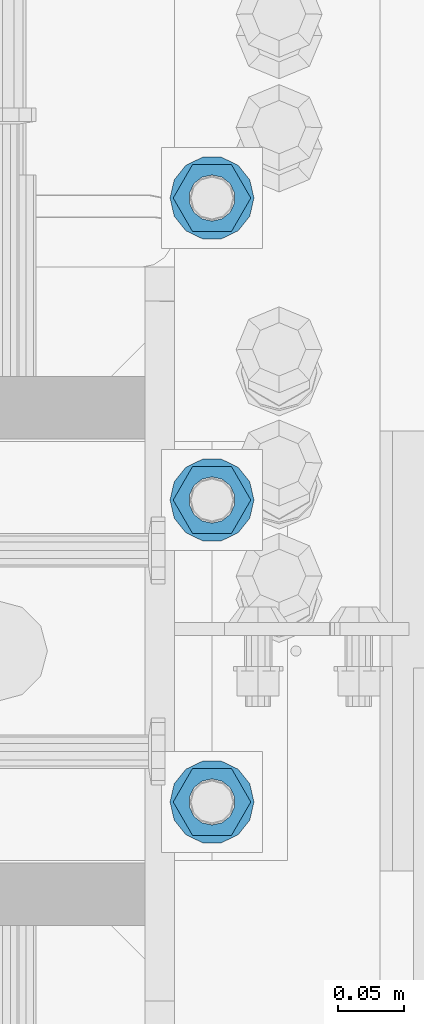
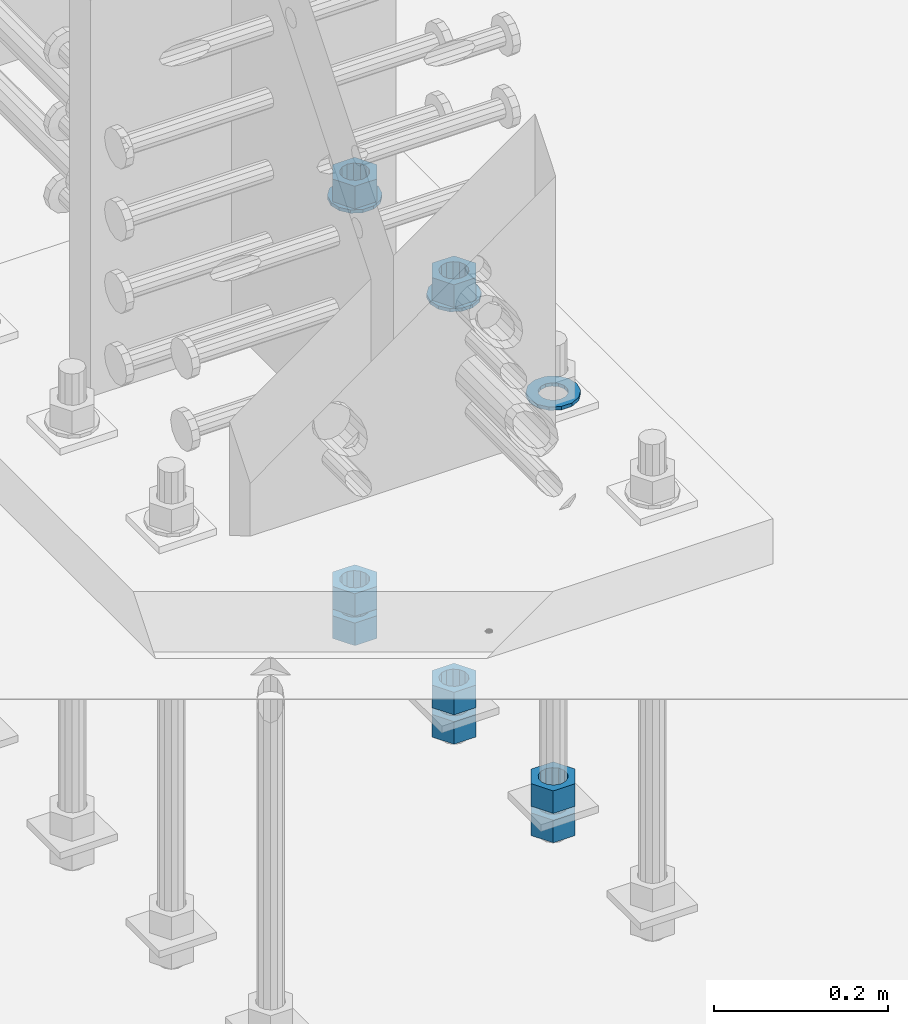
# One storey, part 1009 of 1763: 11 columns, 1 element without a shape of its own.
"""IFC2X3 building model written with IfcOpenShell, lengths in millimetres."""

import ifcopenshell
import ifcopenshell.guid

model = None  # the IFC model being written
_history = None  # IfcOwnerHistory: only IFC2X3 demands one
_inside = {}  # id of a spatial element -> (the spatial element, [elements in it])
_under = {}  # id of a project, library or spatial element -> (it, [spatial elements below it])
_declared = {}  # id of a project -> (the project, [libraries it declares])
_typed = {}  # id of a type object -> (the type object, [elements of that type])
_made_of = {}  # id of a material, layer set ... -> (it, [elements and type objects made of it])


def new_model(schema):
    """Start an empty IFC model of exactly this schema.

    Asked for "IFC4X3", IfcOpenShell would pick the latest addendum, in which some entities
    have other attributes; the version numbers below select the first issue.
    IFC2X3 requires an IfcOwnerHistory on every rooted entity: one is made here for all.
    """
    global model, _history
    if schema == "IFC4X3":
        model = ifcopenshell.file(schema_version=(4, 3, 0, 0))
    else:
        model = ifcopenshell.file(schema=schema)
    _inside.clear()
    _under.clear()
    _declared.clear()
    _typed.clear()
    _made_of.clear()
    _history = None
    if model.schema == "IFC2X3":
        org = make("IfcOrganization", Name="unknown")
        user = make(
            "IfcPersonAndOrganization",
            ThePerson=make("IfcPerson", FamilyName="unknown"),
            TheOrganization=org,
        )
        app = make(
            "IfcApplication",
            ApplicationDeveloper=org,
            Version="unknown",
            ApplicationFullName="unknown",
            ApplicationIdentifier="unknown",
        )
        _history = make(
            "IfcOwnerHistory",
            OwningUser=user,
            OwningApplication=app,
            ChangeAction="ADDED",
            CreationDate=0,
        )
    return model


def make(cls, **values):
    """One entity of the class cls with the attributes given. An attribute that is None is left unset."""
    return model.create_entity(
        cls, **{name: value for name, value in values.items() if value is not None}
    )


def rooted(cls, **values):
    """An entity with a GlobalId (a new one), such as an element, a storey or a relation."""
    return make(cls, GlobalId=ifcopenshell.guid.new(), OwnerHistory=_history, **values)


def si_unit(unit_type, name, prefix=None):
    """IfcSIUnit, for example si_unit("LENGTHUNIT", "METRE", prefix="MILLI")."""
    return make("IfcSIUnit", UnitType=unit_type, Prefix=prefix, Name=name)


def assignment(units):
    """IfcUnitAssignment: the units of a project."""
    return None if units is None else make("IfcUnitAssignment", Units=units)


def point(xyz):
    """IfcCartesianPoint."""
    return None if xyz is None else make("IfcCartesianPoint", Coordinates=xyz)


def direction(xyz):
    """IfcDirection."""
    return None if xyz is None else make("IfcDirection", DirectionRatios=xyz)


def frame(location, z_axis=None, x_axis=None):
    """IfcAxis2Placement3D, a coordinate frame: its origin and axes. An axis left out is left unset."""
    return make(
        "IfcAxis2Placement3D",
        Location=point(location),
        Axis=direction(z_axis),
        RefDirection=direction(x_axis),
    )


def origin_with_axes():
    """The frame at (0, 0, 0) with the z axis (0, 0, 1) and the x axis (1, 0, 0) written out."""
    return frame((0.0, 0.0, 0.0), z_axis=(0.0, 0.0, 1.0), x_axis=(1.0, 0.0, 0.0))


def place(relative_to, where):
    """IfcLocalPlacement: puts the frame where relative to a parent placement (None: the world)."""
    return make(
        "IfcLocalPlacement", PlacementRelTo=relative_to, RelativePlacement=where
    )


def context(
    kind, dimensions, precision=None, world=None, true_north=None, identifier=None
):
    """IfcGeometricRepresentationContext, for example the 3D "Model" context."""
    return make(
        "IfcGeometricRepresentationContext",
        ContextIdentifier=identifier,
        ContextType=kind,
        CoordinateSpaceDimension=dimensions,
        Precision=precision,
        WorldCoordinateSystem=world,
        TrueNorth=true_north,
    )


def subcontext(parent, identifier, kind, view, scale=None):
    """IfcGeometricRepresentationSubContext, for example "Body" below "Model"."""
    return make(
        "IfcGeometricRepresentationSubContext",
        ContextIdentifier=identifier,
        ContextType=kind,
        ParentContext=parent,
        TargetScale=scale,
        TargetView=view,
    )


def project(units=None, contexts=None):
    """IfcProject with its units and contexts."""
    return rooted(
        "IfcProject",
        Name="project",
        RepresentationContexts=contexts,
        UnitsInContext=assignment(units),
    )


def spatial(cls, under=None, at=None, **own):
    """A site, building, storey or space (cls), placed at a placement, below another one or the project."""
    s = rooted(cls, ObjectPlacement=at, **own)
    if under is not None:
        _under.setdefault(under.id(), (under, []))[1].append(s)
    return s


def faces_of(points, faces, orient=None, outer=None):
    """IfcFace entities. A face is a list of loops; a loop is a list of indices into points, from 0.

    orient and outer hold one flag for each loop. By default every Orientation is true, the
    first loop of a face is its IfcFaceOuterBound and the others are IfcFaceBound.
    """
    made = []
    for i, loops in enumerate(faces):
        bounds = []
        for j, loop in enumerate(loops):
            is_outer = j == 0 if outer is None else outer[i][j]
            bounds.append(
                make(
                    "IfcFaceOuterBound" if is_outer else "IfcFaceBound",
                    Bound=make("IfcPolyLoop", Polygon=[points[k] for k in loop]),
                    Orientation=True if orient is None else orient[i][j],
                )
            )
        made.append(make("IfcFace", Bounds=bounds))
    return made


def faceted_brep(points, faces, orient=None, outer=None, voids=None):
    """IfcFacetedBrep: a solid bounded by flat faces; with voids (closed shells), ...WithVoids."""
    shared = [point(p) for p in points]
    hull = make("IfcClosedShell", CfsFaces=faces_of(shared, faces, orient, outer))
    if voids is None:
        return make("IfcFacetedBrep", Outer=hull)
    return make(
        "IfcFacetedBrepWithVoids",
        Outer=hull,
        Voids=[
            make(cls, CfsFaces=faces_of(shared, fs, o, b)) for cls, fs, o, b in voids
        ],
    )


def shape(context_of_items, identifier, shape_type, items):
    """IfcShapeRepresentation: the items that make up one representation, for example the "Body"."""
    return make(
        "IfcShapeRepresentation",
        ContextOfItems=context_of_items,
        RepresentationIdentifier=identifier,
        RepresentationType=shape_type,
        Items=items,
    )


def material(Name=None, Category=None):
    """IfcMaterial."""
    return make("IfcMaterial", Name=Name, Category=Category)


def made_of(thing, what):
    """Note that an element or type object is made of a material, layer set ...; save() writes the relation."""
    if what is not None:
        _made_of.setdefault(what.id(), (what, []))[1].append(thing)
    return thing


def type_object(cls, material=None, **own):
    """A type object (cls), such as IfcWallType, which elements share."""
    return made_of(rooted(cls, **own), material)


def element(
    cls,
    number,
    at=None,
    inside=None,
    cuts=None,
    type_object=None,
    material=None,
    context=None,
    identifier="Body",
    shape_type=None,
    held_by="IfcProductDefinitionShape",
    body=None,
    shapes=None,
    **own,
):
    """One element of the class cls, such as IfcWall. Its Tag is "e" and its number.

    at: its placement. inside: the storey or other place that contains it. cuts: it is an
    opening in that element (IfcRelVoidsElement). A single representation is given by context,
    identifier, shape_type and body (its items); several are given by shapes. held_by: the class
    of the entity that holds the representations. save() writes the other relations.
    """
    e = rooted(cls, Tag="e%d" % number, ObjectPlacement=at, **own)
    if body is not None:
        shapes = [shape(context, identifier, shape_type, body)]
    if shapes is not None:
        e.Representation = make(held_by, Representations=shapes)
    if inside is not None:
        _inside.setdefault(inside.id(), (inside, []))[1].append(e)
    if cuts is not None:
        rooted(
            "IfcRelVoidsElement", RelatingBuildingElement=cuts, RelatedOpeningElement=e
        )
    if type_object is not None:
        _typed.setdefault(type_object.id(), (type_object, []))[1].append(e)
    return made_of(e, material)


def aggregate(whole, parts):
    """IfcRelAggregates: a whole, such as a stair, and the parts it consists of."""
    return rooted("IfcRelAggregates", RelatingObject=whole, RelatedObjects=parts)


def save(model, path):
    """Write the relations noted so far, then the file.

    IfcRelAggregates (storeys below a building ...), IfcRelContainedInSpatialStructure (elements
    in a storey), IfcRelDefinesByType, IfcRelAssociatesMaterial and IfcRelDeclares: one each for
    every whole, place, type object, material and project.
    """
    for whole, parts in _under.values():
        aggregate(whole, parts)
    for where, things in _inside.values():
        rooted(
            "IfcRelContainedInSpatialStructure",
            RelatedElements=things,
            RelatingStructure=where,
        )
    for kind, things in _typed.values():
        rooted("IfcRelDefinesByType", RelatedObjects=things, RelatingType=kind)
    for what, things in _made_of.values():
        rooted("IfcRelAssociatesMaterial", RelatedObjects=things, RelatingMaterial=what)
    for by, libraries in _declared.values():
        rooted("IfcRelDeclares", RelatingContext=by, RelatedDefinitions=libraries)
    model.write(path)


model = new_model("IFC2X3")

# Units and contexts
model_context = context("Model", 3, precision=1e-05, world=origin_with_axes())
body_context = subcontext(model_context, "Body", "Model", "MODEL_VIEW")
ifc_project = project(units=[si_unit("LENGTHUNIT", "METRE", prefix="MILLI"), si_unit("AREAUNIT", "SQUARE_METRE"), si_unit("VOLUMEUNIT", "CUBIC_METRE"), si_unit("MASSUNIT", "GRAM", prefix="KILO"), si_unit("TIMEUNIT", "SECOND"), si_unit("PLANEANGLEUNIT", "RADIAN"), si_unit("SOLIDANGLEUNIT", "STERADIAN"), si_unit("THERMODYNAMICTEMPERATUREUNIT", "DEGREE_CELSIUS"), si_unit("LUMINOUSINTENSITYUNIT", "LUMEN")], contexts=[model_context])

# Site, building, storey
site_placement = place(None, origin_with_axes())
site = spatial("IfcSite", under=ifc_project, at=site_placement, CompositionType="ELEMENT")
building_placement = place(site_placement, origin_with_axes())
building = spatial("IfcBuilding", under=site, at=building_placement, Name="Undefined", CompositionType="ELEMENT")
storey_placement = place(building_placement, origin_with_axes())
storey = spatial("IfcBuildingStorey", under=building, at=storey_placement, Name="Undefined", CompositionType="ELEMENT", Elevation=0.0)

# Assembly, columns
assembly_placement = place(storey_placement, origin_with_axes())
assembly = element("IfcElementAssembly", 1, at=assembly_placement, inside=storey, Name="TEMPLATE", AssemblyPlace="NOTDEFINED", PredefinedType="RIGID_FRAME")
ifc_material_1 = material(Name="STEEL/A563")
column_type_1 = type_object("IfcColumnType", Name="1-1/4_HEAVY_HEX_NUT", PredefinedType="NOTDEFINED")
column_1_placement = place(assembly_placement, frame((-23773.8372736984, -13830.3000000001, 3384.55), z_axis=(0.0, 1.0, 0.0), x_axis=(0.0, 0.0, -1.0)))
column_1 = element("IfcColumn", 2, at=column_1_placement, type_object=column_type_1, material=ifc_material_1, Name="NUT", ObjectType="1-1/4_HEAVY_HEX_NUT", context=body_context, shape_type="Brep", body=[
    faceted_brep([(0.0, -29.3700008392334, 0.0), (0.0, -14.6800003051758, -25.4300003051758), (31.75, -14.6800003051758, -25.4300003051758), (31.75, -29.3700008392334, 0.0), (0.0, 14.6800003051758, -25.4300003051758), (31.75, 14.6800003051758, -25.4300003051758), (0.0, 29.3700008392334, 0.0), (31.75, 29.3700008392334, 0.0), (0.0, 14.6800003051758, 25.4300003051758), (31.75, 14.6800003051758, 25.4300003051758), (0.0, -14.6800003051758, 25.4300003051758), (31.75, -14.6800003051758, 25.4300003051758), (0.0, 0.0, 17.4599990844727), (0.0, 7.57560968776022, 15.730915608714), (31.75, 7.57560968775942, 15.7309156087145), (31.75, 0.0, 17.4599990844727), (0.0, 13.6507769681037, 10.8861313696252), (31.75, 13.6507769681048, 10.8861313696314), (0.0, 17.0222404541215, 3.88521530314756), (31.75, 17.02224045412, 3.88521530315316), (0.0, 17.0222404541215, -3.88521530314756), (31.75, 17.02224045412, -3.88521530315332), (0.0, 13.6507769681037, -10.8861313696252), (31.75, 13.6507769681048, -10.8861313696316), (0.0, 7.57560968776022, -15.730915608714), (31.75, 7.57560968775942, -15.7309156087146), (0.0, 0.0, -17.4599990844727), (31.75, 0.0, -17.4599990844727), (0.0, -7.57560968776022, -15.730915608714), (31.75, -7.57560968775942, -15.7309156087145), (0.0, -13.6507769681037, -10.8861313696252), (31.75, -13.6507769681048, -10.8861313696314), (0.0, -17.0222404541215, -3.88521530314756), (31.75, -17.02224045412, -3.88521530315316), (0.0, -17.0222404541215, 3.88521530314756), (31.75, -17.02224045412, 3.88521530315332), (0.0, -13.6507769681037, 10.8861313696252), (31.75, -13.6507769681048, 10.8861313696316), (0.0, -7.57560968776022, 15.730915608714), (31.75, -7.57560968775942, 15.7309156087146)], [[[0, 1, 2, 3]], [[1, 4, 5, 2]], [[4, 6, 7, 5]], [[6, 8, 9, 7]], [[8, 10, 11, 9]], [[10, 0, 3, 11]], [[12, 13, 14, 15]], [[13, 16, 17, 14]], [[16, 18, 19, 17]], [[18, 20, 21, 19]], [[20, 22, 23, 21]], [[22, 24, 25, 23]], [[24, 26, 27, 25]], [[26, 28, 29, 27]], [[28, 30, 31, 29]], [[30, 32, 33, 31]], [[32, 34, 35, 33]], [[34, 36, 37, 35]], [[36, 38, 39, 37]], [[38, 12, 15, 39]], [[5, 7, 9, 11, 3, 2], [17, 19, 21, 23, 25, 27, 29, 31, 33, 35, 37, 39, 15, 14]], [[10, 8, 6, 4, 1, 0], [38, 36, 34, 32, 30, 28, 26, 24, 22, 20, 18, 16, 13, 12]]]),
])
column_2_placement = place(assembly_placement, frame((-23773.8372736984, -13830.3000000001, 3343.275), z_axis=(0.0, 1.0, 0.0), x_axis=(0.0, 0.0, -1.0)))
column_2 = element("IfcColumn", 3, at=column_2_placement, type_object=column_type_1, material=ifc_material_1, Name="NUT", ObjectType="1-1/4_HEAVY_HEX_NUT", context=body_context, shape_type="Brep", body=[
    faceted_brep([(0.0, -29.3700008392334, 0.0), (0.0, -14.6800003051758, -25.4300003051758), (31.75, -14.6800003051758, -25.4300003051758), (31.75, -29.3700008392334, 0.0), (0.0, 14.6800003051758, -25.4300003051758), (31.75, 14.6800003051758, -25.4300003051758), (0.0, 29.3700008392334, 0.0), (31.75, 29.3700008392334, 0.0), (0.0, 14.6800003051758, 25.4300003051758), (31.75, 14.6800003051758, 25.4300003051758), (0.0, -14.6800003051758, 25.4300003051758), (31.75, -14.6800003051758, 25.4300003051758), (0.0, 0.0, 17.4599990844727), (0.0, 7.57560968776022, 15.730915608714), (31.75, 7.57560968775942, 15.7309156087145), (31.75, 0.0, 17.4599990844727), (0.0, 13.6507769681037, 10.8861313696252), (31.75, 13.6507769681048, 10.8861313696314), (0.0, 17.0222404541215, 3.88521530314756), (31.75, 17.02224045412, 3.88521530315316), (0.0, 17.0222404541215, -3.88521530314756), (31.75, 17.02224045412, -3.88521530315332), (0.0, 13.6507769681037, -10.8861313696252), (31.75, 13.6507769681048, -10.8861313696316), (0.0, 7.57560968776022, -15.730915608714), (31.75, 7.57560968775942, -15.7309156087146), (0.0, 0.0, -17.4599990844727), (31.75, 0.0, -17.4599990844727), (0.0, -7.57560968776022, -15.730915608714), (31.75, -7.57560968775942, -15.7309156087145), (0.0, -13.6507769681037, -10.8861313696252), (31.75, -13.6507769681048, -10.8861313696314), (0.0, -17.0222404541215, -3.88521530314756), (31.75, -17.02224045412, -3.88521530315316), (0.0, -17.0222404541215, 3.88521530314756), (31.75, -17.02224045412, 3.88521530315332), (0.0, -13.6507769681037, 10.8861313696252), (31.75, -13.6507769681048, 10.8861313696316), (0.0, -7.57560968776022, 15.730915608714), (31.75, -7.57560968775942, 15.7309156087146)], [[[0, 1, 2, 3]], [[1, 4, 5, 2]], [[4, 6, 7, 5]], [[6, 8, 9, 7]], [[8, 10, 11, 9]], [[10, 0, 3, 11]], [[12, 13, 14, 15]], [[13, 16, 17, 14]], [[16, 18, 19, 17]], [[18, 20, 21, 19]], [[20, 22, 23, 21]], [[22, 24, 25, 23]], [[24, 26, 27, 25]], [[26, 28, 29, 27]], [[28, 30, 31, 29]], [[30, 32, 33, 31]], [[32, 34, 35, 33]], [[34, 36, 37, 35]], [[36, 38, 39, 37]], [[38, 12, 15, 39]], [[5, 7, 9, 11, 3, 2], [17, 19, 21, 23, 25, 27, 29, 31, 33, 35, 37, 39, 15, 14]], [[10, 8, 6, 4, 1, 0], [38, 36, 34, 32, 30, 28, 26, 24, 22, 20, 18, 16, 13, 12]]]),
])
column_3_placement = place(assembly_placement, frame((-23773.8372736984, -13601.7000000001, 3957.6375), z_axis=(0.0, 1.0, 0.0), x_axis=(0.0, 0.0, -1.0)))
column_3 = element("IfcColumn", 4, at=column_3_placement, type_object=column_type_1, material=ifc_material_1, Name="NUT", ObjectType="1-1/4_HEAVY_HEX_NUT", context=body_context, shape_type="Brep", body=[
    faceted_brep([(0.0, -29.3700008392334, 0.0), (0.0, -14.6800003051758, -25.4300003051758), (31.75, -14.6800003051758, -25.4300003051758), (31.75, -29.3700008392334, 0.0), (0.0, 14.6800003051758, -25.4300003051758), (31.75, 14.6800003051758, -25.4300003051758), (0.0, 29.3700008392334, 0.0), (31.75, 29.3700008392334, 0.0), (0.0, 14.6800003051758, 25.4300003051758), (31.75, 14.6800003051758, 25.4300003051758), (0.0, -14.6800003051758, 25.4300003051758), (31.75, -14.6800003051758, 25.4300003051758), (0.0, 0.0, 17.4599990844727), (0.0, 7.57560968776022, 15.730915608714), (31.75, 7.57560968775942, 15.7309156087145), (31.75, 0.0, 17.4599990844727), (0.0, 13.6507769681037, 10.8861313696252), (31.75, 13.6507769681048, 10.8861313696314), (0.0, 17.0222404541215, 3.88521530314756), (31.75, 17.02224045412, 3.88521530315316), (0.0, 17.0222404541215, -3.88521530314756), (31.75, 17.02224045412, -3.88521530315332), (0.0, 13.6507769681037, -10.8861313696252), (31.75, 13.6507769681048, -10.8861313696316), (0.0, 7.57560968776022, -15.730915608714), (31.75, 7.57560968775942, -15.7309156087146), (0.0, 0.0, -17.4599990844727), (31.75, 0.0, -17.4599990844727), (0.0, -7.57560968776022, -15.730915608714), (31.75, -7.57560968775942, -15.7309156087145), (0.0, -13.6507769681037, -10.8861313696252), (31.75, -13.6507769681048, -10.8861313696314), (0.0, -17.0222404541215, -3.88521530314756), (31.75, -17.02224045412, -3.88521530315316), (0.0, -17.0222404541215, 3.88521530314756), (31.75, -17.02224045412, 3.88521530315332), (0.0, -13.6507769681037, 10.8861313696252), (31.75, -13.6507769681048, 10.8861313696316), (0.0, -7.57560968776022, 15.730915608714), (31.75, -7.57560968775942, 15.7309156087146)], [[[0, 1, 2, 3]], [[1, 4, 5, 2]], [[4, 6, 7, 5]], [[6, 8, 9, 7]], [[8, 10, 11, 9]], [[10, 0, 3, 11]], [[12, 13, 14, 15]], [[13, 16, 17, 14]], [[16, 18, 19, 17]], [[18, 20, 21, 19]], [[20, 22, 23, 21]], [[22, 24, 25, 23]], [[24, 26, 27, 25]], [[26, 28, 29, 27]], [[28, 30, 31, 29]], [[30, 32, 33, 31]], [[32, 34, 35, 33]], [[34, 36, 37, 35]], [[36, 38, 39, 37]], [[38, 12, 15, 39]], [[5, 7, 9, 11, 3, 2], [17, 19, 21, 23, 25, 27, 29, 31, 33, 35, 37, 39, 15, 14]], [[10, 8, 6, 4, 1, 0], [38, 36, 34, 32, 30, 28, 26, 24, 22, 20, 18, 16, 13, 12]]]),
])
column_4_placement = place(assembly_placement, frame((-23773.8372736984, -13601.7000000001, 3384.55), z_axis=(0.0, 1.0, 0.0), x_axis=(0.0, 0.0, -1.0)))
column_4 = element("IfcColumn", 5, at=column_4_placement, type_object=column_type_1, material=ifc_material_1, Name="NUT", ObjectType="1-1/4_HEAVY_HEX_NUT", context=body_context, shape_type="Brep", body=[
    faceted_brep([(0.0, -29.3700008392334, 0.0), (0.0, -14.6800003051758, -25.4300003051758), (31.75, -14.6800003051758, -25.4300003051758), (31.75, -29.3700008392334, 0.0), (0.0, 14.6800003051758, -25.4300003051758), (31.75, 14.6800003051758, -25.4300003051758), (0.0, 29.3700008392334, 0.0), (31.75, 29.3700008392334, 0.0), (0.0, 14.6800003051758, 25.4300003051758), (31.75, 14.6800003051758, 25.4300003051758), (0.0, -14.6800003051758, 25.4300003051758), (31.75, -14.6800003051758, 25.4300003051758), (0.0, 0.0, 17.4599990844727), (0.0, 7.57560968776022, 15.730915608714), (31.75, 7.57560968775942, 15.7309156087145), (31.75, 0.0, 17.4599990844727), (0.0, 13.6507769681037, 10.8861313696252), (31.75, 13.6507769681048, 10.8861313696314), (0.0, 17.0222404541215, 3.88521530314756), (31.75, 17.02224045412, 3.88521530315316), (0.0, 17.0222404541215, -3.88521530314756), (31.75, 17.02224045412, -3.88521530315332), (0.0, 13.6507769681037, -10.8861313696252), (31.75, 13.6507769681048, -10.8861313696316), (0.0, 7.57560968776022, -15.730915608714), (31.75, 7.57560968775942, -15.7309156087146), (0.0, 0.0, -17.4599990844727), (31.75, 0.0, -17.4599990844727), (0.0, -7.57560968776022, -15.730915608714), (31.75, -7.57560968775942, -15.7309156087145), (0.0, -13.6507769681037, -10.8861313696252), (31.75, -13.6507769681048, -10.8861313696314), (0.0, -17.0222404541215, -3.88521530314756), (31.75, -17.02224045412, -3.88521530315316), (0.0, -17.0222404541215, 3.88521530314756), (31.75, -17.02224045412, 3.88521530315332), (0.0, -13.6507769681037, 10.8861313696252), (31.75, -13.6507769681048, 10.8861313696316), (0.0, -7.57560968776022, 15.730915608714), (31.75, -7.57560968775942, 15.7309156087146)], [[[0, 1, 2, 3]], [[1, 4, 5, 2]], [[4, 6, 7, 5]], [[6, 8, 9, 7]], [[8, 10, 11, 9]], [[10, 0, 3, 11]], [[12, 13, 14, 15]], [[13, 16, 17, 14]], [[16, 18, 19, 17]], [[18, 20, 21, 19]], [[20, 22, 23, 21]], [[22, 24, 25, 23]], [[24, 26, 27, 25]], [[26, 28, 29, 27]], [[28, 30, 31, 29]], [[30, 32, 33, 31]], [[32, 34, 35, 33]], [[34, 36, 37, 35]], [[36, 38, 39, 37]], [[38, 12, 15, 39]], [[5, 7, 9, 11, 3, 2], [17, 19, 21, 23, 25, 27, 29, 31, 33, 35, 37, 39, 15, 14]], [[10, 8, 6, 4, 1, 0], [38, 36, 34, 32, 30, 28, 26, 24, 22, 20, 18, 16, 13, 12]]]),
])
column_5_placement = place(assembly_placement, frame((-23773.8372736984, -13601.7000000001, 3343.275), z_axis=(0.0, 1.0, 0.0), x_axis=(0.0, 0.0, -1.0)))
column_5 = element("IfcColumn", 6, at=column_5_placement, type_object=column_type_1, material=ifc_material_1, Name="NUT", ObjectType="1-1/4_HEAVY_HEX_NUT", context=body_context, shape_type="Brep", body=[
    faceted_brep([(0.0, -29.3700008392334, 0.0), (0.0, -14.6800003051758, -25.4300003051758), (31.75, -14.6800003051758, -25.4300003051758), (31.75, -29.3700008392334, 0.0), (0.0, 14.6800003051758, -25.4300003051758), (31.75, 14.6800003051758, -25.4300003051758), (0.0, 29.3700008392334, 0.0), (31.75, 29.3700008392334, 0.0), (0.0, 14.6800003051758, 25.4300003051758), (31.75, 14.6800003051758, 25.4300003051758), (0.0, -14.6800003051758, 25.4300003051758), (31.75, -14.6800003051758, 25.4300003051758), (0.0, 0.0, 17.4599990844727), (0.0, 7.57560968776022, 15.730915608714), (31.75, 7.57560968775942, 15.7309156087145), (31.75, 0.0, 17.4599990844727), (0.0, 13.6507769681037, 10.8861313696252), (31.75, 13.6507769681048, 10.8861313696314), (0.0, 17.0222404541215, 3.88521530314756), (31.75, 17.02224045412, 3.88521530315316), (0.0, 17.0222404541215, -3.88521530314756), (31.75, 17.02224045412, -3.88521530315332), (0.0, 13.6507769681037, -10.8861313696252), (31.75, 13.6507769681048, -10.8861313696316), (0.0, 7.57560968776022, -15.730915608714), (31.75, 7.57560968775942, -15.7309156087146), (0.0, 0.0, -17.4599990844727), (31.75, 0.0, -17.4599990844727), (0.0, -7.57560968776022, -15.730915608714), (31.75, -7.57560968775942, -15.7309156087145), (0.0, -13.6507769681037, -10.8861313696252), (31.75, -13.6507769681048, -10.8861313696314), (0.0, -17.0222404541215, -3.88521530314756), (31.75, -17.02224045412, -3.88521530315316), (0.0, -17.0222404541215, 3.88521530314756), (31.75, -17.02224045412, 3.88521530315332), (0.0, -13.6507769681037, 10.8861313696252), (31.75, -13.6507769681048, 10.8861313696316), (0.0, -7.57560968776022, 15.730915608714), (31.75, -7.57560968775942, 15.7309156087146)], [[[0, 1, 2, 3]], [[1, 4, 5, 2]], [[4, 6, 7, 5]], [[6, 8, 9, 7]], [[8, 10, 11, 9]], [[10, 0, 3, 11]], [[12, 13, 14, 15]], [[13, 16, 17, 14]], [[16, 18, 19, 17]], [[18, 20, 21, 19]], [[20, 22, 23, 21]], [[22, 24, 25, 23]], [[24, 26, 27, 25]], [[26, 28, 29, 27]], [[28, 30, 31, 29]], [[30, 32, 33, 31]], [[32, 34, 35, 33]], [[34, 36, 37, 35]], [[36, 38, 39, 37]], [[38, 12, 15, 39]], [[5, 7, 9, 11, 3, 2], [17, 19, 21, 23, 25, 27, 29, 31, 33, 35, 37, 39, 15, 14]], [[10, 8, 6, 4, 1, 0], [38, 36, 34, 32, 30, 28, 26, 24, 22, 20, 18, 16, 13, 12]]]),
])
column_6_placement = place(assembly_placement, frame((-23773.8372736984, -13373.1000000001, 3957.6375), z_axis=(0.0, 1.0, 0.0), x_axis=(0.0, 0.0, -1.0)))
column_6 = element("IfcColumn", 7, at=column_6_placement, type_object=column_type_1, material=ifc_material_1, Name="NUT", ObjectType="1-1/4_HEAVY_HEX_NUT", context=body_context, shape_type="Brep", body=[
    faceted_brep([(0.0, -29.3700008392334, 0.0), (0.0, -14.6800003051758, -25.4300003051758), (31.75, -14.6800003051758, -25.4300003051758), (31.75, -29.3700008392334, 0.0), (0.0, 14.6800003051758, -25.4300003051758), (31.75, 14.6800003051758, -25.4300003051758), (0.0, 29.3700008392334, 0.0), (31.75, 29.3700008392334, 0.0), (0.0, 14.6800003051758, 25.4300003051758), (31.75, 14.6800003051758, 25.4300003051758), (0.0, -14.6800003051758, 25.4300003051758), (31.75, -14.6800003051758, 25.4300003051758), (0.0, 0.0, 17.4599990844727), (0.0, 7.57560968776022, 15.730915608714), (31.75, 7.57560968775942, 15.7309156087145), (31.75, 0.0, 17.4599990844727), (0.0, 13.6507769681037, 10.8861313696252), (31.75, 13.6507769681048, 10.8861313696314), (0.0, 17.0222404541215, 3.88521530314756), (31.75, 17.02224045412, 3.88521530315316), (0.0, 17.0222404541215, -3.88521530314756), (31.75, 17.02224045412, -3.88521530315332), (0.0, 13.6507769681037, -10.8861313696252), (31.75, 13.6507769681048, -10.8861313696316), (0.0, 7.57560968776022, -15.730915608714), (31.75, 7.57560968775942, -15.7309156087146), (0.0, 0.0, -17.4599990844727), (31.75, 0.0, -17.4599990844727), (0.0, -7.57560968776022, -15.730915608714), (31.75, -7.57560968775942, -15.7309156087145), (0.0, -13.6507769681037, -10.8861313696252), (31.75, -13.6507769681048, -10.8861313696314), (0.0, -17.0222404541215, -3.88521530314756), (31.75, -17.02224045412, -3.88521530315316), (0.0, -17.0222404541215, 3.88521530314756), (31.75, -17.02224045412, 3.88521530315332), (0.0, -13.6507769681037, 10.8861313696252), (31.75, -13.6507769681048, 10.8861313696316), (0.0, -7.57560968776022, 15.730915608714), (31.75, -7.57560968775942, 15.7309156087146)], [[[0, 1, 2, 3]], [[1, 4, 5, 2]], [[4, 6, 7, 5]], [[6, 8, 9, 7]], [[8, 10, 11, 9]], [[10, 0, 3, 11]], [[12, 13, 14, 15]], [[13, 16, 17, 14]], [[16, 18, 19, 17]], [[18, 20, 21, 19]], [[20, 22, 23, 21]], [[22, 24, 25, 23]], [[24, 26, 27, 25]], [[26, 28, 29, 27]], [[28, 30, 31, 29]], [[30, 32, 33, 31]], [[32, 34, 35, 33]], [[34, 36, 37, 35]], [[36, 38, 39, 37]], [[38, 12, 15, 39]], [[5, 7, 9, 11, 3, 2], [17, 19, 21, 23, 25, 27, 29, 31, 33, 35, 37, 39, 15, 14]], [[10, 8, 6, 4, 1, 0], [38, 36, 34, 32, 30, 28, 26, 24, 22, 20, 18, 16, 13, 12]]]),
])
column_7_placement = place(assembly_placement, frame((-23773.8372736984, -13373.1000000001, 3384.55), z_axis=(0.0, 1.0, 0.0), x_axis=(0.0, 0.0, -1.0)))
column_7 = element("IfcColumn", 8, at=column_7_placement, type_object=column_type_1, material=ifc_material_1, Name="NUT", ObjectType="1-1/4_HEAVY_HEX_NUT", context=body_context, shape_type="Brep", body=[
    faceted_brep([(0.0, -29.3700008392334, 0.0), (0.0, -14.6800003051758, -25.4300003051758), (31.75, -14.6800003051758, -25.4300003051758), (31.75, -29.3700008392334, 0.0), (0.0, 14.6800003051758, -25.4300003051758), (31.75, 14.6800003051758, -25.4300003051758), (0.0, 29.3700008392334, 0.0), (31.75, 29.3700008392334, 0.0), (0.0, 14.6800003051758, 25.4300003051758), (31.75, 14.6800003051758, 25.4300003051758), (0.0, -14.6800003051758, 25.4300003051758), (31.75, -14.6800003051758, 25.4300003051758), (0.0, 0.0, 17.4599990844727), (0.0, 7.57560968776022, 15.730915608714), (31.75, 7.57560968775942, 15.7309156087145), (31.75, 0.0, 17.4599990844727), (0.0, 13.6507769681037, 10.8861313696252), (31.75, 13.6507769681048, 10.8861313696314), (0.0, 17.0222404541215, 3.88521530314756), (31.75, 17.02224045412, 3.88521530315316), (0.0, 17.0222404541215, -3.88521530314756), (31.75, 17.02224045412, -3.88521530315332), (0.0, 13.6507769681037, -10.8861313696252), (31.75, 13.6507769681048, -10.8861313696316), (0.0, 7.57560968776022, -15.730915608714), (31.75, 7.57560968775942, -15.7309156087146), (0.0, 0.0, -17.4599990844727), (31.75, 0.0, -17.4599990844727), (0.0, -7.57560968776022, -15.730915608714), (31.75, -7.57560968775942, -15.7309156087145), (0.0, -13.6507769681037, -10.8861313696252), (31.75, -13.6507769681048, -10.8861313696314), (0.0, -17.0222404541215, -3.88521530314756), (31.75, -17.02224045412, -3.88521530315316), (0.0, -17.0222404541215, 3.88521530314756), (31.75, -17.02224045412, 3.88521530315332), (0.0, -13.6507769681037, 10.8861313696252), (31.75, -13.6507769681048, 10.8861313696316), (0.0, -7.57560968776022, 15.730915608714), (31.75, -7.57560968775942, 15.7309156087146)], [[[0, 1, 2, 3]], [[1, 4, 5, 2]], [[4, 6, 7, 5]], [[6, 8, 9, 7]], [[8, 10, 11, 9]], [[10, 0, 3, 11]], [[12, 13, 14, 15]], [[13, 16, 17, 14]], [[16, 18, 19, 17]], [[18, 20, 21, 19]], [[20, 22, 23, 21]], [[22, 24, 25, 23]], [[24, 26, 27, 25]], [[26, 28, 29, 27]], [[28, 30, 31, 29]], [[30, 32, 33, 31]], [[32, 34, 35, 33]], [[34, 36, 37, 35]], [[36, 38, 39, 37]], [[38, 12, 15, 39]], [[5, 7, 9, 11, 3, 2], [17, 19, 21, 23, 25, 27, 29, 31, 33, 35, 37, 39, 15, 14]], [[10, 8, 6, 4, 1, 0], [38, 36, 34, 32, 30, 28, 26, 24, 22, 20, 18, 16, 13, 12]]]),
])
column_8_placement = place(assembly_placement, frame((-23773.8372736984, -13373.1000000001, 3343.275), z_axis=(0.0, 1.0, 0.0), x_axis=(0.0, 0.0, -1.0)))
column_8 = element("IfcColumn", 9, at=column_8_placement, type_object=column_type_1, material=ifc_material_1, Name="NUT", ObjectType="1-1/4_HEAVY_HEX_NUT", context=body_context, shape_type="Brep", body=[
    faceted_brep([(0.0, -29.3700008392334, 0.0), (0.0, -14.6800003051758, -25.4300003051758), (31.75, -14.6800003051758, -25.4300003051758), (31.75, -29.3700008392334, 0.0), (0.0, 14.6800003051758, -25.4300003051758), (31.75, 14.6800003051758, -25.4300003051758), (0.0, 29.3700008392334, 0.0), (31.75, 29.3700008392334, 0.0), (0.0, 14.6800003051758, 25.4300003051758), (31.75, 14.6800003051758, 25.4300003051758), (0.0, -14.6800003051758, 25.4300003051758), (31.75, -14.6800003051758, 25.4300003051758), (0.0, 0.0, 17.4599990844727), (0.0, 7.57560968776022, 15.730915608714), (31.75, 7.57560968775942, 15.7309156087145), (31.75, 0.0, 17.4599990844727), (0.0, 13.6507769681037, 10.8861313696252), (31.75, 13.6507769681048, 10.8861313696314), (0.0, 17.0222404541215, 3.88521530314756), (31.75, 17.02224045412, 3.88521530315316), (0.0, 17.0222404541215, -3.88521530314756), (31.75, 17.02224045412, -3.88521530315332), (0.0, 13.6507769681037, -10.8861313696252), (31.75, 13.6507769681048, -10.8861313696316), (0.0, 7.57560968776022, -15.730915608714), (31.75, 7.57560968775942, -15.7309156087146), (0.0, 0.0, -17.4599990844727), (31.75, 0.0, -17.4599990844727), (0.0, -7.57560968776022, -15.730915608714), (31.75, -7.57560968775942, -15.7309156087145), (0.0, -13.6507769681037, -10.8861313696252), (31.75, -13.6507769681048, -10.8861313696314), (0.0, -17.0222404541215, -3.88521530314756), (31.75, -17.02224045412, -3.88521530315316), (0.0, -17.0222404541215, 3.88521530314756), (31.75, -17.02224045412, 3.88521530315332), (0.0, -13.6507769681037, 10.8861313696252), (31.75, -13.6507769681048, 10.8861313696316), (0.0, -7.57560968776022, 15.730915608714), (31.75, -7.57560968775942, 15.7309156087146)], [[[0, 1, 2, 3]], [[1, 4, 5, 2]], [[4, 6, 7, 5]], [[6, 8, 9, 7]], [[8, 10, 11, 9]], [[10, 0, 3, 11]], [[12, 13, 14, 15]], [[13, 16, 17, 14]], [[16, 18, 19, 17]], [[18, 20, 21, 19]], [[20, 22, 23, 21]], [[22, 24, 25, 23]], [[24, 26, 27, 25]], [[26, 28, 29, 27]], [[28, 30, 31, 29]], [[30, 32, 33, 31]], [[32, 34, 35, 33]], [[34, 36, 37, 35]], [[36, 38, 39, 37]], [[38, 12, 15, 39]], [[5, 7, 9, 11, 3, 2], [17, 19, 21, 23, 25, 27, 29, 31, 33, 35, 37, 39, 15, 14]], [[10, 8, 6, 4, 1, 0], [38, 36, 34, 32, 30, 28, 26, 24, 22, 20, 18, 16, 13, 12]]]),
])
ifc_material_2 = material(Name="STEEL/F436")
column_type_2 = type_object("IfcColumnType", Name="1-1/4_WASHER", PredefinedType="NOTDEFINED")
column_9_placement = place(assembly_placement, frame((-23773.8372736984, -13830.3000000001, 3925.8875), z_axis=(0.0, 1.0, 0.0), x_axis=(0.0, 0.0, -1.0)))
column_9 = element("IfcColumn", 10, at=column_9_placement, type_object=column_type_2, material=ifc_material_2, Name="WASHER", ObjectType="1-1/4_WASHER", context=body_context, shape_type="Brep", body=[
    faceted_brep([(-4.54747350886464e-13, -31.7499999999964, 0.0), (0.0, -28.6057615559002, -13.7758087169827), (4.76249999999982, -28.6057615559002, -13.7758087169827), (4.76249999999982, -31.75, 0.0), (0.0, -19.795801209013, -24.8231495683602), (4.76249999999982, -19.795801209013, -24.8231495683602), (0.0, -7.06503965311276, -30.9539612117732), (4.76249999999982, -7.06503965311276, -30.9539612117732), (0.0, 7.06503965311276, -30.9539612117732), (4.76249999999982, 7.06503965311276, -30.9539612117732), (0.0, 19.7958012090166, -24.8231495683602), (4.76249999999982, 19.7958012090166, -24.8231495683602), (0.0, 28.6057615559039, -13.7758087169827), (4.76249999999982, 28.6057615559039, -13.7758087169827), (-5.91171556152403e-12, 31.7499999999891, 0.0), (4.76249999999982, 31.75, 0.0), (0.0, 28.6057615559002, 13.7758087169827), (4.76249999999982, 28.6057615559002, 13.7758087169827), (0.0, 19.795801209013, 24.8231495683602), (4.76249999999982, 19.795801209013, 24.8231495683602), (0.0, 7.06503965311276, 30.9539612117731), (4.76249999999982, 7.06503965311276, 30.9539612117731), (0.0, -7.06503965311276, 30.9539612117731), (4.76249999999982, -7.06503965311276, 30.9539612117731), (0.0, -19.7958012090166, 24.8231495683602), (4.76249999999982, -19.7958012090166, 24.8231495683602), (0.0, -28.6057615559039, 13.7758087169827), (4.76249999999982, -28.6057615559039, 13.7758087169827), (0.0, 0.0, 17.4599990844727), (0.0, 7.57560968776022, 15.730915608714), (4.76249999999982, 7.57560968775942, 15.7309156087145), (4.76249999999982, 0.0, 17.4599990844727), (0.0, 13.6507769681037, 10.8861313696252), (4.76249999999982, 13.6507769681048, 10.8861313696314), (0.0, 17.0222404541215, 3.88521530314756), (4.76249999999982, 17.02224045412, 3.88521530315316), (0.0, 17.0222404541215, -3.88521530314756), (4.76249999999982, 17.02224045412, -3.88521530315332), (0.0, 13.6507769681037, -10.8861313696252), (4.76249999999982, 13.6507769681048, -10.8861313696316), (0.0, 7.57560968776022, -15.730915608714), (4.76249999999982, 7.57560968775942, -15.7309156087146), (0.0, 0.0, -17.4599990844727), (4.76249999999982, 0.0, -17.4599990844727), (0.0, -7.57560968776022, -15.730915608714), (4.76249999999982, -7.57560968775942, -15.7309156087145), (0.0, -13.6507769681037, -10.8861313696252), (4.76249999999982, -13.6507769681048, -10.8861313696314), (0.0, -17.0222404541215, -3.88521530314756), (4.76249999999982, -17.02224045412, -3.88521530315316), (0.0, -17.0222404541215, 3.88521530314756), (4.76249999999982, -17.02224045412, 3.88521530315332), (0.0, -13.6507769681037, 10.8861313696252), (4.76249999999982, -13.6507769681048, 10.8861313696316), (0.0, -7.57560968776022, 15.730915608714), (4.76249999999982, -7.57560968775942, 15.7309156087146)], [[[0, 1, 2, 3]], [[1, 4, 5, 2]], [[4, 6, 7, 5]], [[6, 8, 9, 7]], [[8, 10, 11, 9]], [[10, 12, 13, 11]], [[12, 14, 15, 13]], [[14, 16, 17, 15]], [[16, 18, 19, 17]], [[18, 20, 21, 19]], [[20, 22, 23, 21]], [[22, 24, 25, 23]], [[24, 26, 27, 25]], [[26, 0, 3, 27]], [[28, 29, 30, 31]], [[29, 32, 33, 30]], [[32, 34, 35, 33]], [[34, 36, 37, 35]], [[36, 38, 39, 37]], [[38, 40, 41, 39]], [[40, 42, 43, 41]], [[42, 44, 45, 43]], [[44, 46, 47, 45]], [[46, 48, 49, 47]], [[48, 50, 51, 49]], [[50, 52, 53, 51]], [[52, 54, 55, 53]], [[54, 28, 31, 55]], [[5, 7, 9, 11, 13, 15, 17, 19, 21, 23, 25, 27, 3, 2], [33, 35, 37, 39, 41, 43, 45, 47, 49, 51, 53, 55, 31, 30]], [[26, 24, 22, 20, 18, 16, 14, 12, 10, 8, 6, 4, 1, 0], [54, 52, 50, 48, 46, 44, 42, 40, 38, 36, 34, 32, 29, 28]]]),
])
column_10_placement = place(assembly_placement, frame((-23773.8372736984, -13601.7000000001, 3925.8875), z_axis=(0.0, 1.0, 0.0), x_axis=(0.0, 0.0, -1.0)))
column_10 = element("IfcColumn", 11, at=column_10_placement, type_object=column_type_2, material=ifc_material_2, Name="WASHER", ObjectType="1-1/4_WASHER", context=body_context, shape_type="Brep", body=[
    faceted_brep([(-4.54747350886464e-13, -31.7499999999964, 0.0), (0.0, -28.6057615559002, -13.7758087169827), (4.76249999999982, -28.6057615559002, -13.7758087169827), (4.76249999999982, -31.75, 0.0), (0.0, -19.795801209013, -24.8231495683602), (4.76249999999982, -19.795801209013, -24.8231495683602), (0.0, -7.06503965311276, -30.9539612117732), (4.76249999999982, -7.06503965311276, -30.9539612117732), (0.0, 7.06503965311276, -30.9539612117732), (4.76249999999982, 7.06503965311276, -30.9539612117732), (0.0, 19.7958012090166, -24.8231495683602), (4.76249999999982, 19.7958012090166, -24.8231495683602), (0.0, 28.6057615559039, -13.7758087169827), (4.76249999999982, 28.6057615559039, -13.7758087169827), (-5.91171556152403e-12, 31.7499999999891, 0.0), (4.76249999999982, 31.75, 0.0), (0.0, 28.6057615559002, 13.7758087169827), (4.76249999999982, 28.6057615559002, 13.7758087169827), (0.0, 19.795801209013, 24.8231495683602), (4.76249999999982, 19.795801209013, 24.8231495683602), (0.0, 7.06503965311276, 30.9539612117731), (4.76249999999982, 7.06503965311276, 30.9539612117731), (0.0, -7.06503965311276, 30.9539612117731), (4.76249999999982, -7.06503965311276, 30.9539612117731), (0.0, -19.7958012090166, 24.8231495683602), (4.76249999999982, -19.7958012090166, 24.8231495683602), (0.0, -28.6057615559039, 13.7758087169827), (4.76249999999982, -28.6057615559039, 13.7758087169827), (0.0, 0.0, 17.4599990844727), (0.0, 7.57560968776022, 15.730915608714), (4.76249999999982, 7.57560968775942, 15.7309156087145), (4.76249999999982, 0.0, 17.4599990844727), (0.0, 13.6507769681037, 10.8861313696252), (4.76249999999982, 13.6507769681048, 10.8861313696314), (0.0, 17.0222404541215, 3.88521530314756), (4.76249999999982, 17.02224045412, 3.88521530315316), (0.0, 17.0222404541215, -3.88521530314756), (4.76249999999982, 17.02224045412, -3.88521530315332), (0.0, 13.6507769681037, -10.8861313696252), (4.76249999999982, 13.6507769681048, -10.8861313696316), (0.0, 7.57560968776022, -15.730915608714), (4.76249999999982, 7.57560968775942, -15.7309156087146), (0.0, 0.0, -17.4599990844727), (4.76249999999982, 0.0, -17.4599990844727), (0.0, -7.57560968776022, -15.730915608714), (4.76249999999982, -7.57560968775942, -15.7309156087145), (0.0, -13.6507769681037, -10.8861313696252), (4.76249999999982, -13.6507769681048, -10.8861313696314), (0.0, -17.0222404541215, -3.88521530314756), (4.76249999999982, -17.02224045412, -3.88521530315316), (0.0, -17.0222404541215, 3.88521530314756), (4.76249999999982, -17.02224045412, 3.88521530315332), (0.0, -13.6507769681037, 10.8861313696252), (4.76249999999982, -13.6507769681048, 10.8861313696316), (0.0, -7.57560968776022, 15.730915608714), (4.76249999999982, -7.57560968775942, 15.7309156087146)], [[[0, 1, 2, 3]], [[1, 4, 5, 2]], [[4, 6, 7, 5]], [[6, 8, 9, 7]], [[8, 10, 11, 9]], [[10, 12, 13, 11]], [[12, 14, 15, 13]], [[14, 16, 17, 15]], [[16, 18, 19, 17]], [[18, 20, 21, 19]], [[20, 22, 23, 21]], [[22, 24, 25, 23]], [[24, 26, 27, 25]], [[26, 0, 3, 27]], [[28, 29, 30, 31]], [[29, 32, 33, 30]], [[32, 34, 35, 33]], [[34, 36, 37, 35]], [[36, 38, 39, 37]], [[38, 40, 41, 39]], [[40, 42, 43, 41]], [[42, 44, 45, 43]], [[44, 46, 47, 45]], [[46, 48, 49, 47]], [[48, 50, 51, 49]], [[50, 52, 53, 51]], [[52, 54, 55, 53]], [[54, 28, 31, 55]], [[5, 7, 9, 11, 13, 15, 17, 19, 21, 23, 25, 27, 3, 2], [33, 35, 37, 39, 41, 43, 45, 47, 49, 51, 53, 55, 31, 30]], [[26, 24, 22, 20, 18, 16, 14, 12, 10, 8, 6, 4, 1, 0], [54, 52, 50, 48, 46, 44, 42, 40, 38, 36, 34, 32, 29, 28]]]),
])
column_11_placement = place(assembly_placement, frame((-23773.8372736984, -13373.1000000001, 3925.8875), z_axis=(0.0, 1.0, 0.0), x_axis=(0.0, 0.0, -1.0)))
column_11 = element("IfcColumn", 12, at=column_11_placement, type_object=column_type_2, material=ifc_material_2, Name="WASHER", ObjectType="1-1/4_WASHER", context=body_context, shape_type="Brep", body=[
    faceted_brep([(-4.54747350886464e-13, -31.7499999999964, 0.0), (0.0, -28.6057615559002, -13.7758087169827), (4.76249999999982, -28.6057615559002, -13.7758087169827), (4.76249999999982, -31.75, 0.0), (0.0, -19.795801209013, -24.8231495683602), (4.76249999999982, -19.795801209013, -24.8231495683602), (0.0, -7.06503965311276, -30.9539612117732), (4.76249999999982, -7.06503965311276, -30.9539612117732), (0.0, 7.06503965311276, -30.9539612117732), (4.76249999999982, 7.06503965311276, -30.9539612117732), (0.0, 19.7958012090166, -24.8231495683602), (4.76249999999982, 19.7958012090166, -24.8231495683602), (0.0, 28.6057615559039, -13.7758087169827), (4.76249999999982, 28.6057615559039, -13.7758087169827), (-5.91171556152403e-12, 31.7499999999891, 0.0), (4.76249999999982, 31.75, 0.0), (0.0, 28.6057615559002, 13.7758087169827), (4.76249999999982, 28.6057615559002, 13.7758087169827), (0.0, 19.795801209013, 24.8231495683602), (4.76249999999982, 19.795801209013, 24.8231495683602), (0.0, 7.06503965311276, 30.9539612117731), (4.76249999999982, 7.06503965311276, 30.9539612117731), (0.0, -7.06503965311276, 30.9539612117731), (4.76249999999982, -7.06503965311276, 30.9539612117731), (0.0, -19.7958012090166, 24.8231495683602), (4.76249999999982, -19.7958012090166, 24.8231495683602), (0.0, -28.6057615559039, 13.7758087169827), (4.76249999999982, -28.6057615559039, 13.7758087169827), (0.0, 0.0, 17.4599990844727), (0.0, 7.57560968776022, 15.730915608714), (4.76249999999982, 7.57560968775942, 15.7309156087145), (4.76249999999982, 0.0, 17.4599990844727), (0.0, 13.6507769681037, 10.8861313696252), (4.76249999999982, 13.6507769681048, 10.8861313696314), (0.0, 17.0222404541215, 3.88521530314756), (4.76249999999982, 17.02224045412, 3.88521530315316), (0.0, 17.0222404541215, -3.88521530314756), (4.76249999999982, 17.02224045412, -3.88521530315332), (0.0, 13.6507769681037, -10.8861313696252), (4.76249999999982, 13.6507769681048, -10.8861313696316), (0.0, 7.57560968776022, -15.730915608714), (4.76249999999982, 7.57560968775942, -15.7309156087146), (0.0, 0.0, -17.4599990844727), (4.76249999999982, 0.0, -17.4599990844727), (0.0, -7.57560968776022, -15.730915608714), (4.76249999999982, -7.57560968775942, -15.7309156087145), (0.0, -13.6507769681037, -10.8861313696252), (4.76249999999982, -13.6507769681048, -10.8861313696314), (0.0, -17.0222404541215, -3.88521530314756), (4.76249999999982, -17.02224045412, -3.88521530315316), (0.0, -17.0222404541215, 3.88521530314756), (4.76249999999982, -17.02224045412, 3.88521530315332), (0.0, -13.6507769681037, 10.8861313696252), (4.76249999999982, -13.6507769681048, 10.8861313696316), (0.0, -7.57560968776022, 15.730915608714), (4.76249999999982, -7.57560968775942, 15.7309156087146)], [[[0, 1, 2, 3]], [[1, 4, 5, 2]], [[4, 6, 7, 5]], [[6, 8, 9, 7]], [[8, 10, 11, 9]], [[10, 12, 13, 11]], [[12, 14, 15, 13]], [[14, 16, 17, 15]], [[16, 18, 19, 17]], [[18, 20, 21, 19]], [[20, 22, 23, 21]], [[22, 24, 25, 23]], [[24, 26, 27, 25]], [[26, 0, 3, 27]], [[28, 29, 30, 31]], [[29, 32, 33, 30]], [[32, 34, 35, 33]], [[34, 36, 37, 35]], [[36, 38, 39, 37]], [[38, 40, 41, 39]], [[40, 42, 43, 41]], [[42, 44, 45, 43]], [[44, 46, 47, 45]], [[46, 48, 49, 47]], [[48, 50, 51, 49]], [[50, 52, 53, 51]], [[52, 54, 55, 53]], [[54, 28, 31, 55]], [[5, 7, 9, 11, 13, 15, 17, 19, 21, 23, 25, 27, 3, 2], [33, 35, 37, 39, 41, 43, 45, 47, 49, 51, 53, 55, 31, 30]], [[26, 24, 22, 20, 18, 16, 14, 12, 10, 8, 6, 4, 1, 0], [54, 52, 50, 48, 46, 44, 42, 40, 38, 36, 34, 32, 29, 28]]]),
])
aggregate(assembly, [column_9, column_1, column_2, column_3, column_10, column_4, column_5, column_6, column_11, column_7, column_8])

save(model, "model.ifc")
